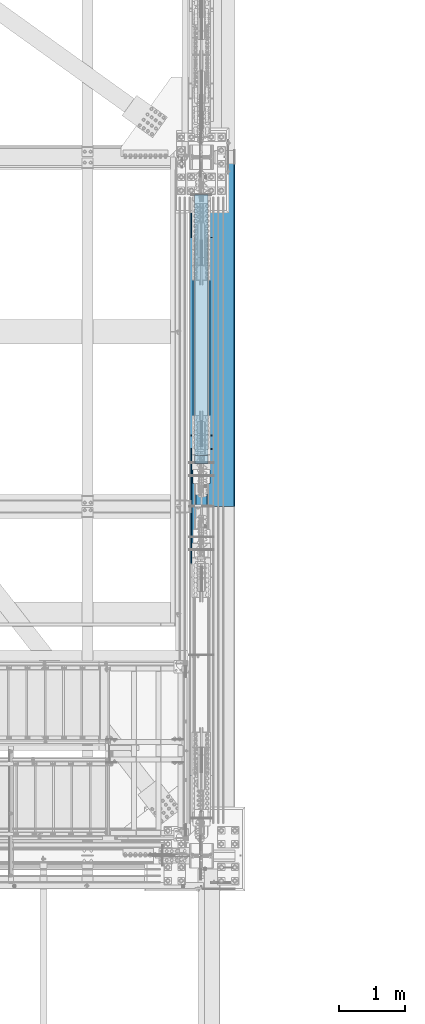
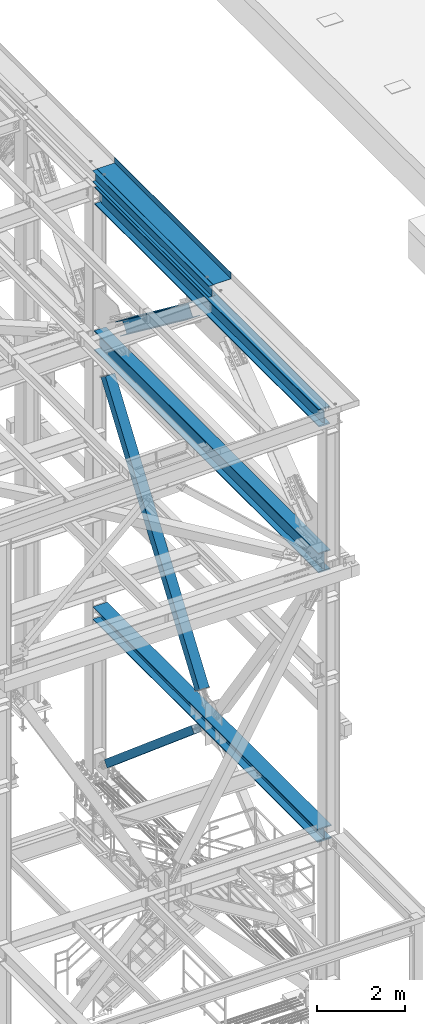
# One storey, part 1953 of 3843: 5 beams, 3 members, 7 elements without a shape of their own.
"""IFC2X3 building model written with IfcOpenShell, lengths in millimetres."""

import ifcopenshell
import ifcopenshell.guid

model = None  # the IFC model being written
_history = None  # IfcOwnerHistory: only IFC2X3 demands one
_inside = {}  # id of a spatial element -> (the spatial element, [elements in it])
_under = {}  # id of a project, library or spatial element -> (it, [spatial elements below it])
_declared = {}  # id of a project -> (the project, [libraries it declares])
_typed = {}  # id of a type object -> (the type object, [elements of that type])
_made_of = {}  # id of a material, layer set ... -> (it, [elements and type objects made of it])


def new_model(schema):
    """Start an empty IFC model of exactly this schema.

    Asked for "IFC4X3", IfcOpenShell would pick the latest addendum, in which some entities
    have other attributes; the version numbers below select the first issue.
    IFC2X3 requires an IfcOwnerHistory on every rooted entity: one is made here for all.
    """
    global model, _history
    if schema == "IFC4X3":
        model = ifcopenshell.file(schema_version=(4, 3, 0, 0))
    else:
        model = ifcopenshell.file(schema=schema)
    _inside.clear()
    _under.clear()
    _declared.clear()
    _typed.clear()
    _made_of.clear()
    _history = None
    if model.schema == "IFC2X3":
        org = make("IfcOrganization", Name="unknown")
        user = make(
            "IfcPersonAndOrganization",
            ThePerson=make("IfcPerson", FamilyName="unknown"),
            TheOrganization=org,
        )
        app = make(
            "IfcApplication",
            ApplicationDeveloper=org,
            Version="unknown",
            ApplicationFullName="unknown",
            ApplicationIdentifier="unknown",
        )
        _history = make(
            "IfcOwnerHistory",
            OwningUser=user,
            OwningApplication=app,
            ChangeAction="ADDED",
            CreationDate=0,
        )
    return model


def make(cls, **values):
    """One entity of the class cls with the attributes given. An attribute that is None is left unset."""
    return model.create_entity(
        cls, **{name: value for name, value in values.items() if value is not None}
    )


def rooted(cls, **values):
    """An entity with a GlobalId (a new one), such as an element, a storey or a relation."""
    return make(cls, GlobalId=ifcopenshell.guid.new(), OwnerHistory=_history, **values)


def si_unit(unit_type, name, prefix=None):
    """IfcSIUnit, for example si_unit("LENGTHUNIT", "METRE", prefix="MILLI")."""
    return make("IfcSIUnit", UnitType=unit_type, Prefix=prefix, Name=name)


def assignment(units):
    """IfcUnitAssignment: the units of a project."""
    return None if units is None else make("IfcUnitAssignment", Units=units)


def point(xyz):
    """IfcCartesianPoint."""
    return None if xyz is None else make("IfcCartesianPoint", Coordinates=xyz)


def direction(xyz):
    """IfcDirection."""
    return None if xyz is None else make("IfcDirection", DirectionRatios=xyz)


def frame(location, z_axis=None, x_axis=None):
    """IfcAxis2Placement3D, a coordinate frame: its origin and axes. An axis left out is left unset."""
    return make(
        "IfcAxis2Placement3D",
        Location=point(location),
        Axis=direction(z_axis),
        RefDirection=direction(x_axis),
    )


def origin_with_axes():
    """The frame at (0, 0, 0) with the z axis (0, 0, 1) and the x axis (1, 0, 0) written out."""
    return frame((0.0, 0.0, 0.0), z_axis=(0.0, 0.0, 1.0), x_axis=(1.0, 0.0, 0.0))


def place(relative_to, where):
    """IfcLocalPlacement: puts the frame where relative to a parent placement (None: the world)."""
    return make(
        "IfcLocalPlacement", PlacementRelTo=relative_to, RelativePlacement=where
    )


def context(
    kind, dimensions, precision=None, world=None, true_north=None, identifier=None
):
    """IfcGeometricRepresentationContext, for example the 3D "Model" context."""
    return make(
        "IfcGeometricRepresentationContext",
        ContextIdentifier=identifier,
        ContextType=kind,
        CoordinateSpaceDimension=dimensions,
        Precision=precision,
        WorldCoordinateSystem=world,
        TrueNorth=true_north,
    )


def subcontext(parent, identifier, kind, view, scale=None):
    """IfcGeometricRepresentationSubContext, for example "Body" below "Model"."""
    return make(
        "IfcGeometricRepresentationSubContext",
        ContextIdentifier=identifier,
        ContextType=kind,
        ParentContext=parent,
        TargetScale=scale,
        TargetView=view,
    )


def project(units=None, contexts=None):
    """IfcProject with its units and contexts."""
    return rooted(
        "IfcProject",
        Name="project",
        RepresentationContexts=contexts,
        UnitsInContext=assignment(units),
    )


def spatial(cls, under=None, at=None, **own):
    """A site, building, storey or space (cls), placed at a placement, below another one or the project."""
    s = rooted(cls, ObjectPlacement=at, **own)
    if under is not None:
        _under.setdefault(under.id(), (under, []))[1].append(s)
    return s


def faces_of(points, faces, orient=None, outer=None):
    """IfcFace entities. A face is a list of loops; a loop is a list of indices into points, from 0.

    orient and outer hold one flag for each loop. By default every Orientation is true, the
    first loop of a face is its IfcFaceOuterBound and the others are IfcFaceBound.
    """
    made = []
    for i, loops in enumerate(faces):
        bounds = []
        for j, loop in enumerate(loops):
            is_outer = j == 0 if outer is None else outer[i][j]
            bounds.append(
                make(
                    "IfcFaceOuterBound" if is_outer else "IfcFaceBound",
                    Bound=make("IfcPolyLoop", Polygon=[points[k] for k in loop]),
                    Orientation=True if orient is None else orient[i][j],
                )
            )
        made.append(make("IfcFace", Bounds=bounds))
    return made


def faceted_brep(points, faces, orient=None, outer=None, voids=None):
    """IfcFacetedBrep: a solid bounded by flat faces; with voids (closed shells), ...WithVoids."""
    shared = [point(p) for p in points]
    hull = make("IfcClosedShell", CfsFaces=faces_of(shared, faces, orient, outer))
    if voids is None:
        return make("IfcFacetedBrep", Outer=hull)
    return make(
        "IfcFacetedBrepWithVoids",
        Outer=hull,
        Voids=[
            make(cls, CfsFaces=faces_of(shared, fs, o, b)) for cls, fs, o, b in voids
        ],
    )


def shape(context_of_items, identifier, shape_type, items):
    """IfcShapeRepresentation: the items that make up one representation, for example the "Body"."""
    return make(
        "IfcShapeRepresentation",
        ContextOfItems=context_of_items,
        RepresentationIdentifier=identifier,
        RepresentationType=shape_type,
        Items=items,
    )


def material(Name=None, Category=None):
    """IfcMaterial."""
    return make("IfcMaterial", Name=Name, Category=Category)


def made_of(thing, what):
    """Note that an element or type object is made of a material, layer set ...; save() writes the relation."""
    if what is not None:
        _made_of.setdefault(what.id(), (what, []))[1].append(thing)
    return thing


def type_object(cls, material=None, **own):
    """A type object (cls), such as IfcWallType, which elements share."""
    return made_of(rooted(cls, **own), material)


def element(
    cls,
    number,
    at=None,
    inside=None,
    cuts=None,
    type_object=None,
    material=None,
    context=None,
    identifier="Body",
    shape_type=None,
    held_by="IfcProductDefinitionShape",
    body=None,
    shapes=None,
    **own,
):
    """One element of the class cls, such as IfcWall. Its Tag is "e" and its number.

    at: its placement. inside: the storey or other place that contains it. cuts: it is an
    opening in that element (IfcRelVoidsElement). A single representation is given by context,
    identifier, shape_type and body (its items); several are given by shapes. held_by: the class
    of the entity that holds the representations. save() writes the other relations.
    """
    e = rooted(cls, Tag="e%d" % number, ObjectPlacement=at, **own)
    if body is not None:
        shapes = [shape(context, identifier, shape_type, body)]
    if shapes is not None:
        e.Representation = make(held_by, Representations=shapes)
    if inside is not None:
        _inside.setdefault(inside.id(), (inside, []))[1].append(e)
    if cuts is not None:
        rooted(
            "IfcRelVoidsElement", RelatingBuildingElement=cuts, RelatedOpeningElement=e
        )
    if type_object is not None:
        _typed.setdefault(type_object.id(), (type_object, []))[1].append(e)
    return made_of(e, material)


def aggregate(whole, parts):
    """IfcRelAggregates: a whole, such as a stair, and the parts it consists of."""
    return rooted("IfcRelAggregates", RelatingObject=whole, RelatedObjects=parts)


def save(model, path):
    """Write the relations noted so far, then the file.

    IfcRelAggregates (storeys below a building ...), IfcRelContainedInSpatialStructure (elements
    in a storey), IfcRelDefinesByType, IfcRelAssociatesMaterial and IfcRelDeclares: one each for
    every whole, place, type object, material and project.
    """
    for whole, parts in _under.values():
        aggregate(whole, parts)
    for where, things in _inside.values():
        rooted(
            "IfcRelContainedInSpatialStructure",
            RelatedElements=things,
            RelatingStructure=where,
        )
    for kind, things in _typed.values():
        rooted("IfcRelDefinesByType", RelatedObjects=things, RelatingType=kind)
    for what, things in _made_of.values():
        rooted("IfcRelAssociatesMaterial", RelatedObjects=things, RelatingMaterial=what)
    for by, libraries in _declared.values():
        rooted("IfcRelDeclares", RelatingContext=by, RelatedDefinitions=libraries)
    model.write(path)


model = new_model("IFC2X3")

# Units and contexts
model_context = context("Model", 3, precision=1e-05, world=origin_with_axes())
body_context = subcontext(model_context, "Body", "Model", "MODEL_VIEW")
ifc_project = project(units=[si_unit("LENGTHUNIT", "METRE", prefix="MILLI"), si_unit("AREAUNIT", "SQUARE_METRE"), si_unit("VOLUMEUNIT", "CUBIC_METRE"), si_unit("MASSUNIT", "GRAM", prefix="KILO"), si_unit("TIMEUNIT", "SECOND"), si_unit("PLANEANGLEUNIT", "RADIAN"), si_unit("SOLIDANGLEUNIT", "STERADIAN"), si_unit("THERMODYNAMICTEMPERATUREUNIT", "DEGREE_CELSIUS"), si_unit("LUMINOUSINTENSITYUNIT", "LUMEN")], contexts=[model_context])

# Site, building, storey
site_placement = place(None, origin_with_axes())
site = spatial("IfcSite", under=ifc_project, at=site_placement, CompositionType="ELEMENT")
building_placement = place(site_placement, origin_with_axes())
building = spatial("IfcBuilding", under=site, at=building_placement, Name="Undefined", CompositionType="ELEMENT")
storey_placement = place(building_placement, origin_with_axes())
storey = spatial("IfcBuildingStorey", under=building, at=storey_placement, Name="Undefined", CompositionType="ELEMENT", Elevation=0.0)

# Assembly, beam
assembly_1_placement = place(storey_placement, origin_with_axes())
assembly_1 = element("IfcElementAssembly", 1, at=assembly_1_placement, inside=storey, Name="BEAM", AssemblyPlace="NOTDEFINED", PredefinedType="RIGID_FRAME")
ifc_material_1 = material(Name="STEEL/A992")
beam_type_1 = type_object("IfcBeamType", Name="W12X26", PredefinedType="NOTDEFINED")
beam_1_placement = place(assembly_1_placement, frame((85648.8000000003, 20307.3, 46612.1749999998), z_axis=(0.0, 0.0, 1.0), x_axis=(0.0, 1.0, 0.0)))
beam_1 = element("IfcBeam", 2, at=beam_1_placement, type_object=beam_type_1, material=ifc_material_1, Name="BEAM", ObjectType="W12X26", context=body_context, shape_type="Brep", body=[
    faceted_brep([(0.0, 82.5500000000029, -155.574999999997), (0.0, 82.5500000000029, -146.050000000003), (5308.6, 82.5500000000029, -146.050000000003), (5308.6, 82.5500000000029, -155.574999999997), (0.0, 3.17500000000291, -146.050000000003), (5308.6, 3.17500000000291, -146.050000000003), (0.0, 3.17500000000291, 146.050000000003), (5308.6, 3.17500000000291, 146.050000000003), (0.0, 82.5500000000029, 146.050000000003), (5308.6, 82.5500000000029, 146.050000000003), (0.0, 82.5500000000029, 155.574999999997), (5308.6, 82.5500000000029, 155.574999999997), (0.0, -82.5500000000029, 155.574999999997), (5308.6, -82.5500000000029, 155.574999999997), (0.0, -82.5500000000029, 146.050000000003), (5308.6, -82.5500000000029, 146.050000000003), (0.0, -3.17500000000291, 146.050000000003), (5308.6, -3.17500000000291, 146.050000000003), (0.0, -3.17500000000291, -146.050000000003), (5308.6, -3.17500000000291, -146.050000000003), (0.0, -82.5500000000029, -146.050000000003), (5308.6, -82.5500000000029, -146.050000000003), (0.0, -82.5500000000029, -155.574999999997), (5308.6, -82.5500000000029, -155.574999999997)], [[[0, 1, 2, 3]], [[1, 4, 5, 2]], [[4, 6, 7, 5]], [[6, 8, 9, 7]], [[8, 10, 11, 9]], [[10, 12, 13, 11]], [[12, 14, 15, 13]], [[14, 16, 17, 15]], [[16, 18, 19, 17]], [[18, 20, 21, 19]], [[20, 22, 23, 21]], [[22, 0, 3, 23]], [[5, 7, 9, 11, 13, 15, 17, 19, 21, 23, 3, 2]], [[22, 20, 18, 16, 14, 12, 10, 8, 6, 4, 1, 0]]]),
])

assembly_2_placement = place(storey_placement, origin_with_axes())
assembly_2 = element("IfcElementAssembly", 3, at=assembly_2_placement, inside=storey, Name="BEAM", AssemblyPlace="NOTDEFINED", PredefinedType="RIGID_FRAME")
beam_type_2 = type_object("IfcBeamType", Name="W21X101", PredefinedType="NOTDEFINED")
beam_2_placement = place(assembly_2_placement, frame((85648.7999999171, 14998.7, 42197.3375), z_axis=(0.0, 0.0, 1.0), x_axis=(0.0, 1.0, 0.0)))
beam_2 = element("IfcBeam", 4, at=beam_2_placement, type_object=beam_type_2, material=ifc_material_1, Name="BEAM", ObjectType="W21X101", context=body_context, shape_type="Brep", body=[
    faceted_brep([(10421.9375, 6.34999999997672, 215.900000000001), (10414.6051515831, -6.35000000000582, 215.900000000001), (10414.6051515831, -6.35000000000582, -215.900000000001), (10421.9375, 6.35000000000582, -215.900000000001), (195.262500000001, 155.574999999997, 250.824999999997), (207.177101116094, 155.574999999997, 271.462500000001), (10410.0228988839, 155.574999999997, 271.462500000001), (10421.9375, 155.574999999997, 250.824999999997), (195.262500000001, 6.35000000000582, 250.824999999997), (10421.9375, 6.35000000000582, 250.824999999997), (207.177115981647, -155.574999999997, -250.824999999997), (195.262500000001, -155.574999999997, -271.462500000001), (10421.9375, -155.574999999997, -271.462500000001), (10410.0228840184, -155.574999999997, -250.824999999997), (195.262500000001, 155.574999999997, -271.462500000001), (10421.9375, 155.574999999997, -271.462500000001), (207.177115981647, 155.574999999997, -250.824999999997), (10410.0228840184, 155.574999999997, -250.824999999997), (207.177115981647, 6.35000000000582, -250.824999999997), (10410.0228840184, 6.35000000000582, -250.824999999997), (10340.0620692278, -6.35000000000582, -217.357163726287), (10340.0620692278, 6.35000000000582, -217.357163726287), (10345.1252344185, 6.35000000000582, -215.900000000001), (10345.1252344185, -6.35000000000582, -215.900000000001), (10336.5480611922, -6.35000000000582, -221.282812131343), (10336.5480611922, 6.35000000000582, -221.282812131343), (10335.6583778181, -6.35000000000582, -226.475829690324), (10335.6583778181, 6.35000000000582, -226.475829690324), (10337.6652321012, -6.35000000000582, -231.347328818971), (10337.6652321012, 6.35000000000582, -231.347328818971), (10341.9545945649, -6.35000000000582, -234.406795689014), (10341.9545945649, 6.35000000000582, -234.406795689014), (10387.3395, -6.35000000000582, -250.428), (10387.3395, 6.35000000000582, -250.428), (10409.7936920092, -6.35000000000582, -250.428), (10409.7936920092, 6.35000000000582, -250.428), (10410.0228840184, -6.35000000000582, -250.824999999997), (207.177115981647, -6.35000000000582, -250.824999999997), (207.406307990826, -6.35000000000582, -250.428), (207.406307990826, 6.35000000000582, -250.428), (229.860500000004, -6.34999999999127, -250.428), (229.860500000004, 6.35000000000582, -250.428), (275.245405435075, -6.34999999999127, -234.406795689014), (275.245405435075, 6.35000000000582, -234.406795689014), (279.534767898796, -6.34999999999127, -231.347328818971), (279.534767898796, 6.35000000000582, -231.347328818971), (281.5416221819, -6.34999999999127, -226.475829690324), (281.5416221819, 6.35000000000582, -226.475829690324), (280.651938807767, -6.34999999999127, -221.282812131343), (280.651938807767, 6.35000000000582, -221.282812131343), (277.137930772215, -6.34999999999127, -217.357163726287), (277.137930772215, 6.35000000000582, -217.357163726287), (272.074765581463, -6.34999999999127, -215.900000000001), (272.074765581463, 6.35000000000582, -215.900000000001), (202.594848416855, -6.34999999999127, -215.900000000001), (195.262500000001, 6.35000000000582, -215.900000000001), (202.594848416855, -6.34999999999127, 215.900000000001), (195.262500000001, 6.35000000000582, 215.900000000001), (272.401765581464, -6.34999999999127, 215.900000000001), (272.401765581464, 6.35000000000582, 215.900000000001), (277.464930772214, -6.34999999999127, 217.357163726287), (277.464930772214, 6.35000000000582, 217.357163726287), (280.978938807766, -6.34999999999127, 221.282812131351), (280.978938807766, 6.35000000000582, 221.282812131351), (281.868622181899, -6.34999999999127, 226.475829690324), (281.868622181899, 6.35000000000582, 226.475829690324), (279.861767898796, -6.34999999999127, 231.347328818971), (279.861767898796, 6.35000000000582, 231.347328818971), (275.572405435074, -6.34999999999127, 234.406795689014), (275.572405435074, 6.35000000000582, 234.406795689014), (230.187500000004, -6.34999999999127, 250.428), (230.187500000004, 6.35000000000582, 250.428), (195.262500000001, -6.35000000000582, 250.428), (195.262500000001, 6.35000000000582, 250.428), (195.262500000001, -6.35000000000582, 250.824999999997), (207.177101116094, -155.574999999997, 271.462500000001), (195.262500000001, -155.574999999997, 250.824999999997), (10421.9375, -6.35000000000582, 250.824999999997), (10421.9375, -155.574999999997, 250.824999999997), (10410.0228988839, -155.574999999997, 271.462500000001), (10421.9375, -6.35000000000582, 250.428), (10421.9375, 6.35000000000582, 250.428), (10387.0125, -6.35000000000582, 250.428), (10387.0125, 6.35000000000582, 250.428), (10341.6275945649, -6.35000000000582, 234.406795689014), (10341.6275945649, 6.35000000000582, 234.406795689014), (10337.3382321012, -6.35000000000582, 231.347328818971), (10337.3382321012, 6.35000000000582, 231.347328818971), (10335.3313778181, -6.35000000000582, 226.475829690324), (10335.3313778181, 6.35000000000582, 226.475829690324), (10336.2210611922, -6.35000000000582, 221.282812131343), (10336.2210611922, 6.35000000000582, 221.282812131343), (10339.7350692278, -6.35000000000582, 217.357163726287), (10339.7350692278, 6.35000000000582, 217.357163726287), (10344.7982344185, -6.35000000000582, 215.900000000001), (10344.7982344185, 6.35000000000582, 215.900000000001)], [[[0, 1, 2, 3]], [[4, 5, 6, 7]], [[8, 4, 7, 9]], [[10, 11, 12, 13]], [[11, 14, 15, 12]], [[14, 16, 17, 15]], [[16, 18, 19, 17]], [[20, 21, 22, 23]], [[24, 25, 21, 20]], [[26, 27, 25, 24]], [[28, 29, 27, 26]], [[30, 31, 29, 28]], [[32, 33, 31, 30]], [[33, 32, 34, 35]], [[12, 15, 17, 19, 35, 34, 36, 13]], [[37, 10, 13, 36]], [[38, 39, 18, 16, 14, 11, 10, 37]], [[40, 41, 39, 38]], [[42, 43, 41, 40]], [[44, 45, 43, 42]], [[46, 47, 45, 44]], [[48, 49, 47, 46]], [[50, 51, 49, 48]], [[52, 53, 51, 50]], [[54, 55, 53, 52]], [[55, 54, 56, 57]], [[58, 59, 57, 56]], [[60, 61, 59, 58]], [[62, 63, 61, 60]], [[64, 65, 63, 62]], [[66, 67, 65, 64]], [[68, 69, 67, 66]], [[70, 71, 69, 68]], [[71, 70, 72, 73]], [[73, 72, 74, 8]], [[75, 5, 4, 8, 74, 76]], [[76, 74, 77, 78]], [[75, 76, 78, 79]], [[5, 75, 79, 6]], [[78, 77, 9, 7, 6, 79]], [[80, 81, 9, 77]], [[82, 83, 81, 80]], [[84, 85, 83, 82]], [[86, 87, 85, 84]], [[88, 89, 87, 86]], [[90, 91, 89, 88]], [[92, 93, 91, 90]], [[94, 95, 93, 92]], [[22, 21, 25, 27, 29, 31, 33, 35, 19, 18, 39, 41, 43, 45, 47, 49, 51, 53, 55, 57, 59, 61, 63, 65, 67, 69, 71, 73, 8, 9, 81, 83, 85, 87, 89, 91, 93, 95, 0, 3]], [[23, 22, 3, 2]], [[94, 92, 90, 88, 86, 84, 82, 80, 77, 74, 72, 70, 68, 66, 64, 62, 60, 58, 56, 54, 52, 50, 48, 46, 44, 42, 40, 38, 37, 36, 34, 32, 30, 28, 26, 24, 20, 23, 2, 1]], [[95, 94, 1, 0]]]),
])
aggregate(assembly_2, [beam_2])

# Assembly, member
assembly_3_placement = place(storey_placement, origin_with_axes())
assembly_3 = element("IfcElementAssembly", 5, at=assembly_3_placement, inside=storey, Name="None", AssemblyPlace="NOTDEFINED", PredefinedType="RIGID_FRAME")
member_type_1 = type_object("IfcMemberType", Name="HSS8X8X3/16", PredefinedType="NOTDEFINED")
member_1_placement = place(assembly_3_placement, frame((85648.8, 24980.733047223, 30674.2567411832), z_axis=(-1.0, 0.0, 0.0), x_axis=(0.0, -0.76355947920618, 0.645737502174365)))
member_1 = element("IfcMember", 6, at=member_1_placement, type_object=member_type_1, material=ifc_material_1, Name="None", ObjectType="HSS8X8X3/16", context=body_context, shape_type="Brep", body=[
    faceted_brep([(2.03726813197136e-10, 96.8375000003298, -96.8374999999942), (-2.18278728425503e-10, -96.837500000317, -96.8374999999942), (5187.94999995862, -96.8374999935477, -96.8374999999942), (5187.94999995838, 96.8375000062442, -96.8374999999942), (-2.18278728425503e-10, -96.837500000317, 96.8374999999942), (5187.94999995862, -96.8374999935477, 96.8374999999942), (2.03726813197136e-10, 96.8375000003298, 96.8374999999942), (5187.94999995838, 96.8375000062442, 96.8374999999942), (2.18278728425503e-10, 101.600000000345, -101.600000000006), (2.18278728425503e-10, 101.600000000345, 101.600000000006), (5187.94999995837, 101.600000006241, 101.600000000006), (5187.94999995837, 101.600000006241, -101.600000000006), (-2.25554686039686e-10, -101.600000000329, 101.600000000006), (5187.94999995862, -101.599999993537, 101.600000000006), (-2.25554686039686e-10, -101.600000000329, -101.600000000006), (5187.94999995862, -101.599999993537, -101.600000000006)], [[[0, 1, 2, 3]], [[1, 4, 5, 2]], [[4, 6, 7, 5]], [[6, 0, 3, 7]], [[8, 9, 10, 11]], [[9, 12, 13, 10]], [[12, 14, 15, 13]], [[14, 8, 11, 15]], [[13, 15, 11, 10], [5, 7, 3, 2]], [[14, 12, 9, 8], [6, 4, 1, 0]]]),
])
aggregate(assembly_3, [member_1])

assembly_4_placement = place(storey_placement, origin_with_axes())
assembly_4 = element("IfcElementAssembly", 7, at=assembly_4_placement, inside=storey, Name="None", AssemblyPlace="NOTDEFINED", PredefinedType="RIGID_FRAME")
member_type_2 = type_object("IfcMemberType", Name="HSS10X10X1/4", PredefinedType="NOTDEFINED")
member_2_placement = place(assembly_4_placement, frame((85648.8, 20763.0069138488, 35276.450201078), z_axis=(1.0, 0.0, 0.0), x_axis=(0.0, 0.57411894604347, 0.818771907061994)))
member_2 = element("IfcMember", 8, at=member_2_placement, type_object=member_type_2, material=ifc_material_1, Name="None", ObjectType="HSS10X10X1/4", context=body_context, shape_type="Brep", body=[
    faceted_brep([(2.00088834390044e-10, 120.650000000089, -120.649999999994), (-2.03726813197136e-10, -120.650000000081, -120.649999999994), (7473.94999993846, -120.649999995156, -120.649999999994), (7473.94999993832, 120.650000004556, -120.649999999994), (-2.03726813197136e-10, -120.650000000081, 120.649999999994), (7473.94999993846, -120.649999995156, 120.649999999994), (2.00088834390044e-10, 120.650000000089, 120.649999999994), (7473.94999993832, 120.650000004556, 120.649999999994), (2.16459739021957e-10, 127.000000000087, -127.0), (2.16459739021957e-10, 127.000000000087, 127.0), (7473.9499999383, 127.000000004547, 127.0), (7473.9499999383, 127.000000004547, -127.0), (-2.14640749618411e-10, -127.00000000008, 127.0), (7473.94999993846, -126.999999995147, 127.0), (-2.14640749618411e-10, -127.00000000008, -127.0), (7473.94999993846, -126.999999995147, -127.0)], [[[0, 1, 2, 3]], [[1, 4, 5, 2]], [[4, 6, 7, 5]], [[6, 0, 3, 7]], [[8, 9, 10, 11]], [[9, 12, 13, 10]], [[12, 14, 15, 13]], [[14, 8, 11, 15]], [[13, 15, 11, 10], [5, 7, 3, 2]], [[14, 12, 9, 8], [6, 4, 1, 0]]]),
])
aggregate(assembly_4, [member_2])

# Assembly, beam
assembly_5_placement = place(storey_placement, origin_with_axes())
assembly_5 = element("IfcElementAssembly", 9, at=assembly_5_placement, inside=storey, Name="BEAM", AssemblyPlace="NOTDEFINED", PredefinedType="RIGID_FRAME")
beam_type_3 = type_object("IfcBeamType", Name="W14X120", PredefinedType="NOTDEFINED")
beam_3_placement = place(assembly_5_placement, frame((85648.8, 14998.7, 34626.55), z_axis=(0.0, 0.0, 1.0), x_axis=(0.0, 1.0, 0.0)))
beam_3 = element("IfcBeam", 10, at=beam_3_placement, type_object=beam_type_3, material=ifc_material_1, Name="BEAM", ObjectType="W14X120", context=body_context, shape_type="Brep", body=[
    faceted_brep([(203.51139196899, -7.14375000001746, 134.9375), (195.262499999997, 7.14375000000291, 134.9375), (195.262500000004, 7.14375000000291, 115.040000000001), (195.262500000004, 7.14375000000291, -115.040000000001), (195.262499999997, 7.14375000000291, -134.9375), (203.51139196899, -7.14375000000291, -134.9375), (245.449128079592, -7.14375000000291, -134.9375), (245.449128079592, 7.14375000000291, -134.9375), (250.277761093239, 7.14375000000291, -136.252145122373), (250.277761093239, -7.14375000000291, -136.252145122373), (253.773493509842, 7.14375000000291, -139.833184559415), (253.773493509842, -7.14375000000291, -139.833184559415), (254.971359921634, 7.14375000000291, -144.692104669659), (254.971359921634, -7.14375000000291, -144.692104669659), (253.54070010841, 7.14375000000291, -149.487644376197), (253.54070010841, -7.14375000000291, -149.487644376197), (249.876434809397, 7.14375000000291, -152.896038190993), (249.876434809397, -7.14375000000291, -152.896038190993), (236.457500000004, 7.14375000000291, -159.940499999997), (236.457500000004, -7.14375000000291, -159.940499999997), (209.240292719613, 7.14375000000291, -159.940499496464), (209.240292719613, -7.14375000000291, -159.940499496464), (209.011084125363, 7.14375000000291, -160.337500000001), (209.011084125363, 185.737500000003, -160.337500000001), (195.262500000004, 185.737500000003, -184.150000000001), (195.262500000004, -185.737500000003, -184.150000000001), (209.011084125363, -185.737500000003, -160.337500000001), (209.011084125363, -7.14375000000291, -160.337500000001), (10408.1889165666, 7.14375000000291, -160.337500000001), (10408.1889165666, 185.737500000003, -160.337500000001), (10421.9375, 185.737500000003, -184.150000000001), (10421.9375, -185.737500000003, -184.150000000001), (10408.1889165666, -185.737500000003, -160.337500000001), (10408.1889165666, -7.14375000000291, -160.337500000001), (10407.9597082833, 7.14375000000291, -159.940499999997), (10407.9597082833, -7.14375000000291, -159.940499999997), (10380.7425, 7.14375000000291, -159.940499999997), (10380.7425, -7.14375000000291, -159.940499999997), (10367.3235651906, 7.14375000000291, -152.896038190993), (10367.3235651906, -7.14375000000291, -152.896038190993), (10363.6592998916, 7.14375000000291, -149.487644376204), (10363.6592998916, -7.14375000000291, -149.487644376204), (10362.2286400784, 7.14375000000291, -144.692104669659), (10362.2286400784, -7.14375000000291, -144.692104669659), (10363.4265064902, 7.14375000000291, -139.833184559415), (10363.4265064902, -7.14375000000291, -139.833184559415), (10366.9222389068, 7.14375000000291, -136.252145122373), (10366.9222389068, -7.14375000000291, -136.252145122373), (10371.7508719204, 7.14375000000291, -134.9375), (10371.7508719204, -7.14375000000291, -134.9375), (10421.9375, 7.14375000000291, -134.9375), (10413.688608031, -7.14375000000291, -134.9375), (10421.9375, 7.14375000001746, 134.9375), (10413.688608031, -7.14375000000291, 134.9375), (10373.2578719204, 7.14375000000291, 134.9375), (10373.2578719204, -7.14375000000291, 134.9375), (10368.4292389068, 7.14375000000291, 136.252145122373), (10368.4292389068, -7.14375000000291, 136.252145122373), (10364.9335064902, 7.14375000000291, 139.833184559415), (10364.9335064902, -7.14375000000291, 139.833184559415), (10363.7356400784, 7.14375000000291, 144.692104669659), (10363.7356400784, -7.14375000000291, 144.692104669659), (10365.1662998916, 7.14375000000291, 149.487644376197), (10365.1662998916, -7.14375000000291, 149.487644376197), (10368.8305651906, 7.14375000000291, 152.896038190993), (10368.8305651906, -7.14375000000291, 152.896038190993), (10382.2495, 7.14375000000291, 159.940499999997), (10382.2495, -7.14375000000291, 159.940499999997), (10421.9375, 7.14375000000291, 159.940499999997), (10421.9375, -7.14375000000291, 159.940499999997), (10421.9375, 7.14375000000291, 160.337500000001), (10421.9375, -7.14375000000291, 160.337500000001), (195.262500000004, 7.14375000000291, 160.337500000001), (195.262500000004, 185.737500000003, 160.337500000001), (10421.9375, 185.737500000003, 160.337500000001), (209.011071506542, 185.737500000003, 184.150000000001), (10408.188929574, 185.737500000003, 184.150000000001), (209.011071506542, -185.737500000003, 184.150000000001), (195.262500000004, -185.737500000003, 160.337500000001), (10421.9375, -185.737500000003, 160.337500000001), (10408.188929574, -185.737500000003, 184.150000000001), (195.262500000004, -7.14375000000291, 160.337500000001), (195.262500000004, 7.14375000000291, 159.940499496464), (195.262500000004, -7.14375000000291, 159.940499496464), (234.950499999992, 7.14375000000291, 159.940499999997), (234.950499999992, -7.14375000000291, 159.940499999997), (248.369434809385, 7.14375000000291, 152.896038190993), (248.369434809385, -7.14375000000291, 152.896038190993), (252.033700108397, 7.14375000000291, 149.487644376204), (252.033700108397, -7.14375000000291, 149.487644376204), (253.464359921622, 7.14375000000291, 144.692104669659), (253.464359921622, -7.14375000000291, 144.692104669659), (252.266493509844, 7.14375000000291, 139.833184559415), (252.266493509844, -7.14375000000291, 139.833184559415), (248.770761093227, 7.14375000000291, 136.252145122373), (248.770761093227, -7.14375000000291, 136.252145122373), (243.94212807958, 7.14375000000291, 134.9375), (243.94212807958, -7.14375000000291, 134.9375)], [[[0, 1, 2, 3, 4, 5]], [[6, 7, 8, 9]], [[9, 8, 10, 11]], [[11, 10, 12, 13]], [[13, 12, 14, 15]], [[15, 14, 16, 17]], [[17, 16, 18, 19]], [[19, 18, 20, 21]], [[21, 20, 22, 23, 24, 25, 26, 27]], [[23, 22, 28, 29]], [[24, 23, 29, 30]], [[25, 24, 30, 31]], [[26, 25, 31, 32]], [[27, 26, 32, 33]], [[31, 30, 29, 28, 34, 35, 33, 32]], [[36, 37, 35, 34]], [[37, 36, 38, 39]], [[39, 38, 40, 41]], [[41, 40, 42, 43]], [[43, 42, 44, 45]], [[45, 44, 46, 47]], [[47, 46, 48, 49]], [[49, 48, 50, 51]], [[52, 53, 51, 50]], [[54, 55, 53, 52]], [[55, 54, 56, 57]], [[57, 56, 58, 59]], [[59, 58, 60, 61]], [[61, 60, 62, 63]], [[63, 62, 64, 65]], [[65, 64, 66, 67]], [[67, 66, 68, 69]], [[69, 68, 70, 71]], [[72, 73, 74, 70]], [[73, 75, 76, 74]], [[77, 78, 79, 80]], [[75, 77, 80, 76]], [[79, 71, 70, 74, 76, 80]], [[78, 81, 71, 79]], [[77, 75, 73, 72, 81, 78]], [[82, 83, 81, 72]], [[84, 85, 83, 82]], [[85, 84, 86, 87]], [[87, 86, 88, 89]], [[89, 88, 90, 91]], [[91, 90, 92, 93]], [[93, 92, 94, 95]], [[95, 94, 96, 97]], [[6, 9, 11, 13, 15, 17, 19, 21, 27, 33, 35, 37, 39, 41, 43, 45, 47, 49, 51, 53, 55, 57, 59, 61, 63, 65, 67, 69, 71, 81, 83, 85, 87, 89, 91, 93, 95, 97, 0, 5]], [[7, 6, 5, 4]], [[96, 94, 92, 90, 88, 86, 84, 82, 72, 70, 68, 66, 64, 62, 60, 58, 56, 54, 52, 50, 48, 46, 44, 42, 40, 38, 36, 34, 28, 22, 20, 18, 16, 14, 12, 10, 8, 7, 4, 3, 2, 1]], [[97, 96, 1, 0]]]),
])
aggregate(assembly_5, [beam_3])

# Beam
ifc_material_2 = material(Name="STEEL/A36")
beam_type_4 = type_object("IfcBeamType", PredefinedType="NOTDEFINED")
beam_4_placement = place(assembly_1_placement, frame((85680.5500000003, 22961.6, 46772.5124999998), z_axis=(0.0, -1.0, 0.0), x_axis=(1.0, 0.0, 0.0)))
beam_4 = element("IfcBeam", 11, at=beam_4_placement, type_object=beam_type_4, material=ifc_material_2, Name="BENT_PLATE", context=body_context, shape_type="Brep", body=[
    faceted_brep([(466.724999999977, 4.76249999999709, -2651.12500004767), (469.899999952511, 1.58750004768808, -2654.3), (0.0, 1.58750004768808, -2654.3), (0.0, 4.76249999999709, -2651.12500004768), (466.724999999991, 160.337500000009, -2651.12500004767), (469.899999952526, 160.337500000009, -2654.3), (0.0, 4.76249999999709, 2654.3), (466.724999999977, 4.76249999999709, 2654.3), (0.0, -4.76249999999709, -2654.3), (0.0, -4.76249999999709, 2654.3), (476.249999999971, -4.76249999999709, -2654.3), (476.249999999971, -4.76249999999709, 2654.3), (466.724999999991, 160.337500000009, 2654.3), (476.249999999985, 160.337500000009, 2654.3), (476.249999999985, 160.337500000009, -2654.3)], [[[0, 1, 2, 3]], [[4, 5, 1, 0]], [[6, 7, 0, 3]], [[8, 9, 6, 3, 2]], [[9, 8, 10, 11]], [[7, 12, 4, 0]], [[7, 6, 9, 11, 13, 12]], [[11, 10, 14, 13]], [[5, 14, 10, 8, 2, 1]], [[12, 13, 14, 5, 4]]]),
])

aggregate(assembly_1, [beam_4, beam_1])

# Assembly, member
assembly_6_placement = place(storey_placement, origin_with_axes())
assembly_6 = element("IfcElementAssembly", 12, at=assembly_6_placement, inside=storey, AssemblyPlace="NOTDEFINED", PredefinedType="RIGID_FRAME")
member_type_3 = type_object("IfcMemberType", Name="W14X90", PredefinedType="NOTDEFINED")
member_3_placement = place(assembly_6_placement, frame((85648.8000000095, 20307.300000067, 46213.9030425824), z_axis=(0.0, 0.603370707059055, 0.797460839078043), x_axis=(0.0, 0.797460839078044, -0.603370707059054)))
member_3 = element("IfcMember", 13, at=member_3_placement, type_object=member_type_3, material=ifc_material_1, ObjectType="W14X90", context=body_context, shape_type="Brep", body=[
    faceted_brep([(1223.5485367281, 184.149999999994, -177.800000000214), (1223.5485367281, 184.149999999994, -160.337500000191), (4992.74060290396, 184.149999999994, -160.337499999841), (4992.74060290397, 184.149999999994, -177.799999999879), (1223.5485367281, 5.55624999999418, -160.337500000191), (4992.74060290396, 5.55624999999418, -160.337499999841), (1223.54853672811, 5.55624999999418, 160.337500000402), (4992.74060290397, 5.55624999999418, 160.337500000751), (1223.54853672811, 184.149999999994, 160.337500000402), (4992.74060290397, 184.149999999994, 160.337500000751), (1223.5485367281, 184.149999999994, 177.800000000432), (4992.74060290397, 184.149999999994, 177.800000000781), (1223.5485367281, -184.149999999994, 177.800000000432), (4992.74060290397, -184.149999999994, 177.800000000781), (1223.54853672811, -184.149999999994, 160.337500000402), (4992.74060290397, -184.149999999994, 160.337500000751), (1223.54853672811, -5.55624999999418, 160.337500000402), (4992.74060290397, -5.55624999999418, 160.337500000751), (1223.5485367281, -5.55624999999418, -160.337500000191), (4992.74060290396, -5.55624999999418, -160.337499999841), (1223.5485367281, -184.149999999994, -160.337500000191), (4992.74060290396, -184.149999999994, -160.337499999841), (1223.5485367281, -184.149999999994, -177.800000000214), (4992.74060290397, -184.149999999994, -177.799999999879)], [[[0, 1, 2, 3]], [[1, 4, 5, 2]], [[4, 6, 7, 5]], [[6, 8, 9, 7]], [[8, 10, 11, 9]], [[10, 12, 13, 11]], [[12, 14, 15, 13]], [[14, 16, 17, 15]], [[16, 18, 19, 17]], [[18, 20, 21, 19]], [[20, 22, 23, 21]], [[22, 0, 3, 23]], [[5, 7, 9, 11, 13, 15, 17, 19, 21, 23, 3, 2]], [[22, 20, 18, 16, 14, 12, 10, 8, 6, 4, 1, 0]]]),
])
aggregate(assembly_6, [member_3])

# Assembly, beam
assembly_7_placement = place(storey_placement, origin_with_axes())
assembly_7 = element("IfcElementAssembly", 14, at=assembly_7_placement, inside=storey, Name="BEAM", AssemblyPlace="NOTDEFINED", PredefinedType="RIGID_FRAME")
beam_type_5 = type_object("IfcBeamType", Name="W18X119", PredefinedType="NOTDEFINED")
beam_5_placement = place(assembly_7_placement, frame((85648.8, 14998.7, 46215.3), z_axis=(0.0, 0.0, 1.0), x_axis=(0.0, 1.0, 0.0)))
beam_5 = element("IfcBeam", 15, at=beam_5_placement, type_object=beam_type_5, material=ifc_material_1, Name="BEAM", ObjectType="W18X119", context=body_context, shape_type="Brep", body=[
    faceted_brep([(10421.9375, -142.875, 214.3125), (10421.9375, -7.9375, 214.3125), (10421.9375, 7.9375, 214.3125), (10421.9375, 142.875, 214.3125), (10406.3559250386, 142.875, 241.300000000003), (10406.3559250386, -142.875, 241.300000000003), (211.073294146889, -7.9375, -213.915499496463), (211.073294146889, 7.9375, -213.915499496463), (210.844086796831, 7.9375, -214.3125), (210.844086796831, 142.875, -214.3125), (195.262499999983, 142.875, -241.300000000003), (195.262499999983, -142.875, -241.300000000003), (210.844086796831, -142.875, -214.3125), (210.844086796831, -7.9375, -214.3125), (217.652493164045, -7.9375, -213.915499496463), (217.652493164045, 7.9375, -213.915499496463), (270.959123406632, -7.9375, -204.646698168704), (270.959123406632, 7.9375, -204.646698168704), (275.931005797916, -7.9375, -202.126780799372), (275.931005797916, 7.9375, -202.126780799372), (278.641447986083, -7.9375, -197.256144166888), (278.641447986083, 7.9375, -197.256144166888), (278.1622408119, -7.9375, -191.702770548509), (278.1622408119, 7.9375, -191.702770548509), (274.657491995589, -7.9375, -187.368450094778), (274.657491995589, 7.9375, -187.368450094778), (269.327426344069, -7.9375, -185.737500000003), (269.327426344069, 7.9375, -185.737500000003), (198.437499999985, -7.9375, -185.737500000003), (198.437499999985, 7.9375, -185.737500000003), (198.437499999985, -7.9375, 185.737500000003), (198.437499999985, 7.9375, 185.737500000003), (272.337432196291, -7.9375, 185.737500000003), (272.337432196291, 7.9375, 185.737500000003), (277.667497835268, -7.9375, 187.368450086302), (277.667497835268, 7.9375, 187.368450086302), (281.172246652815, -7.9375, 191.702770520424), (281.172246652815, 7.9375, 191.702770520424), (281.651453847808, -7.9375, 197.256144122483), (281.651453847808, 7.9375, 197.256144122483), (278.94101169378, -7.9375, 202.126780757397), (278.94101169378, 7.9375, 202.126780757397), (273.969129333418, -7.9375, 204.646698155739), (273.969129333418, 7.9375, 204.646698155739), (220.662501525861, -7.9375, 213.915499496463), (220.662501525861, 7.9375, 213.915499496463), (195.262499999983, -7.9375, 213.915499496463), (195.262499999983, 7.9375, 213.915499496463), (195.262499999983, -7.9375, 214.3125), (195.262499999983, 7.9375, 214.3125), (210.844074961424, -142.875, 241.300000000003), (210.844074961424, 142.875, 241.300000000003), (195.262499999983, 142.875, 214.3125), (195.262499999983, -142.875, 214.3125), (10421.9375, -7.9375, 213.915499496463), (10421.9375, 7.9375, 213.915499496463), (10396.5374984741, -7.9375, 213.915499496463), (10396.5374984741, 7.9375, 213.915499496463), (10343.2308706666, -7.9375, 204.646698155739), (10343.2308706666, 7.9375, 204.646698155739), (10338.2589883062, -7.9375, 202.126780757397), (10338.2589883062, 7.9375, 202.126780757397), (10335.5485461522, -7.9375, 197.256144122483), (10335.5485461522, 7.9375, 197.256144122483), (10336.0277533472, -7.9375, 191.702770520424), (10336.0277533472, 7.9375, 191.702770520424), (10339.5325021647, -7.9375, 187.368450086302), (10339.5325021647, 7.9375, 187.368450086302), (10344.8625678037, -7.9375, 185.737500000003), (10344.8625678037, 7.9375, 185.737500000003), (10418.7625, -7.9375, 185.737500000003), (10418.7625, 7.9375, 185.737500000003), (10418.7625, -7.9375, -185.737500000003), (10418.7625, 7.9375, -185.737500000003), (10347.8725736559, -7.9375, -185.737500000003), (10347.8725736559, 7.9375, -185.737500000003), (10342.5425080044, -7.9375, -187.368450094778), (10342.5425080044, 7.9375, -187.368450094778), (10339.0377591881, -7.9375, -191.702770548509), (10339.0377591881, 7.9375, -191.702770548509), (10338.5585520139, -7.9375, -197.256144166888), (10338.5585520139, 7.9375, -197.256144166888), (10341.2689942021, -7.9375, -202.126780799372), (10341.2689942021, 7.9375, -202.126780799372), (10346.2408765934, -7.9375, -204.646698168704), (10346.2408765934, 7.9375, -204.646698168704), (10399.5475068359, -7.9375, -213.915499496463), (10399.5475068359, 7.9375, -213.915499496463), (10406.1267058531, -7.9375, -213.915499496463), (10406.1267058531, 7.9375, -213.915499496463), (10406.3559132032, 7.9375, -214.3125), (10406.3559132032, 142.875, -214.3125), (10421.9375, 142.875, -241.300000000003), (10421.9375, -142.875, -241.300000000003), (10406.3559132032, -142.875, -214.3125), (10406.3559132032, -7.9375, -214.3125)], [[[0, 1, 2, 3, 4, 5]], [[6, 7, 8, 9, 10, 11, 12, 13]], [[14, 15, 7, 6]], [[16, 17, 15, 14]], [[18, 19, 17, 16]], [[20, 21, 19, 18]], [[22, 23, 21, 20]], [[24, 25, 23, 22]], [[26, 27, 25, 24]], [[27, 26, 28, 29]], [[30, 31, 29, 28]], [[32, 33, 31, 30]], [[34, 35, 33, 32]], [[36, 37, 35, 34]], [[38, 39, 37, 36]], [[40, 41, 39, 38]], [[42, 43, 41, 40]], [[44, 45, 43, 42]], [[45, 44, 46, 47]], [[47, 46, 48, 49]], [[50, 51, 52, 49, 48, 53]], [[50, 53, 0, 5]], [[51, 50, 5, 4]], [[52, 51, 4, 3]], [[49, 52, 3, 2]], [[54, 55, 2, 1]], [[56, 57, 55, 54]], [[58, 59, 57, 56]], [[60, 61, 59, 58]], [[62, 63, 61, 60]], [[64, 65, 63, 62]], [[66, 67, 65, 64]], [[68, 69, 67, 66]], [[69, 68, 70, 71]], [[70, 72, 73, 71]], [[74, 75, 73, 72]], [[76, 77, 75, 74]], [[78, 79, 77, 76]], [[80, 81, 79, 78]], [[82, 83, 81, 80]], [[84, 85, 83, 82]], [[86, 87, 85, 84]], [[87, 86, 88, 89]], [[8, 7, 15, 17, 19, 21, 23, 25, 27, 29, 31, 33, 35, 37, 39, 41, 43, 45, 47, 49, 2, 55, 57, 59, 61, 63, 65, 67, 69, 71, 73, 75, 77, 79, 81, 83, 85, 87, 89, 90]], [[9, 8, 90, 91]], [[10, 9, 91, 92]], [[11, 10, 92, 93]], [[12, 11, 93, 94]], [[13, 12, 94, 95]], [[93, 92, 91, 90, 89, 88, 95, 94]], [[86, 84, 82, 80, 78, 76, 74, 72, 70, 68, 66, 64, 62, 60, 58, 56, 54, 1, 48, 46, 44, 42, 40, 38, 36, 34, 32, 30, 28, 26, 24, 22, 20, 18, 16, 14, 6, 13, 95, 88]], [[53, 48, 1, 0]]]),
])
aggregate(assembly_7, [beam_5])

save(model, "model.ifc")
